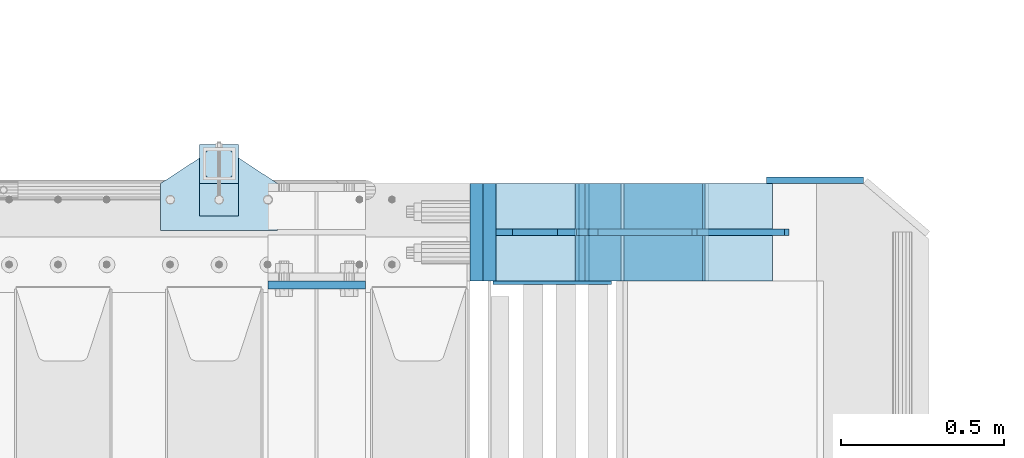
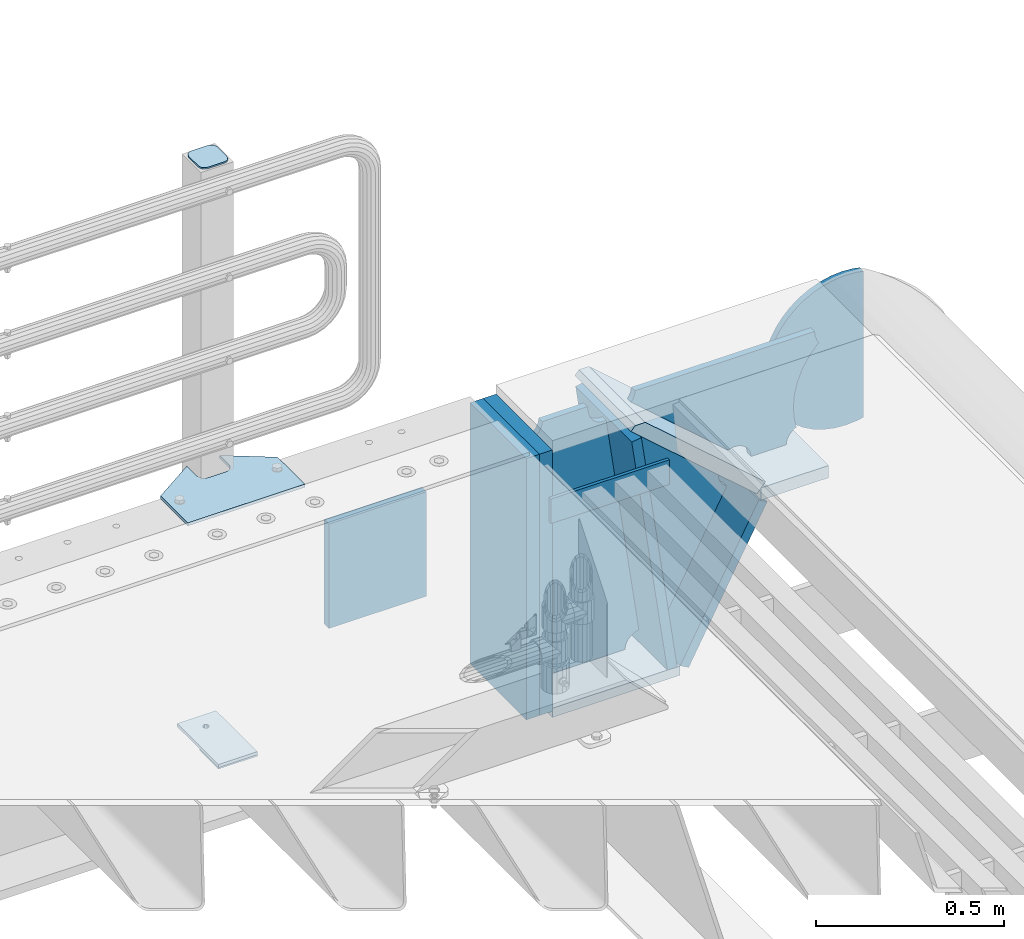
# One storey, part 243 of 257: 17 plates.
"""IFC2X3 building model written with IfcOpenShell, lengths in millimetres."""

import ifcopenshell
import ifcopenshell.guid

model = None  # the IFC model being written
_history = None  # IfcOwnerHistory: only IFC2X3 demands one
_inside = {}  # id of a spatial element -> (the spatial element, [elements in it])
_under = {}  # id of a project, library or spatial element -> (it, [spatial elements below it])
_declared = {}  # id of a project -> (the project, [libraries it declares])
_typed = {}  # id of a type object -> (the type object, [elements of that type])
_made_of = {}  # id of a material, layer set ... -> (it, [elements and type objects made of it])


def new_model(schema):
    """Start an empty IFC model of exactly this schema.

    Asked for "IFC4X3", IfcOpenShell would pick the latest addendum, in which some entities
    have other attributes; the version numbers below select the first issue.
    IFC2X3 requires an IfcOwnerHistory on every rooted entity: one is made here for all.
    """
    global model, _history
    if schema == "IFC4X3":
        model = ifcopenshell.file(schema_version=(4, 3, 0, 0))
    else:
        model = ifcopenshell.file(schema=schema)
    _inside.clear()
    _under.clear()
    _declared.clear()
    _typed.clear()
    _made_of.clear()
    _history = None
    if model.schema == "IFC2X3":
        org = make("IfcOrganization", Name="unknown")
        user = make(
            "IfcPersonAndOrganization",
            ThePerson=make("IfcPerson", FamilyName="unknown"),
            TheOrganization=org,
        )
        app = make(
            "IfcApplication",
            ApplicationDeveloper=org,
            Version="unknown",
            ApplicationFullName="unknown",
            ApplicationIdentifier="unknown",
        )
        _history = make(
            "IfcOwnerHistory",
            OwningUser=user,
            OwningApplication=app,
            ChangeAction="ADDED",
            CreationDate=0,
        )
    return model


def make(cls, **values):
    """One entity of the class cls with the attributes given. An attribute that is None is left unset."""
    return model.create_entity(
        cls, **{name: value for name, value in values.items() if value is not None}
    )


def rooted(cls, **values):
    """An entity with a GlobalId (a new one), such as an element, a storey or a relation."""
    return make(cls, GlobalId=ifcopenshell.guid.new(), OwnerHistory=_history, **values)


def si_unit(unit_type, name, prefix=None):
    """IfcSIUnit, for example si_unit("LENGTHUNIT", "METRE", prefix="MILLI")."""
    return make("IfcSIUnit", UnitType=unit_type, Prefix=prefix, Name=name)


def assignment(units):
    """IfcUnitAssignment: the units of a project."""
    return None if units is None else make("IfcUnitAssignment", Units=units)


def point(xyz):
    """IfcCartesianPoint."""
    return None if xyz is None else make("IfcCartesianPoint", Coordinates=xyz)


def direction(xyz):
    """IfcDirection."""
    return None if xyz is None else make("IfcDirection", DirectionRatios=xyz)


def frame(location, z_axis=None, x_axis=None):
    """IfcAxis2Placement3D, a coordinate frame: its origin and axes. An axis left out is left unset."""
    return make(
        "IfcAxis2Placement3D",
        Location=point(location),
        Axis=direction(z_axis),
        RefDirection=direction(x_axis),
    )


def origin_with_axes():
    """The frame at (0, 0, 0) with the z axis (0, 0, 1) and the x axis (1, 0, 0) written out."""
    return frame((0.0, 0.0, 0.0), z_axis=(0.0, 0.0, 1.0), x_axis=(1.0, 0.0, 0.0))


def place(relative_to, where):
    """IfcLocalPlacement: puts the frame where relative to a parent placement (None: the world)."""
    return make(
        "IfcLocalPlacement", PlacementRelTo=relative_to, RelativePlacement=where
    )


def context(
    kind, dimensions, precision=None, world=None, true_north=None, identifier=None
):
    """IfcGeometricRepresentationContext, for example the 3D "Model" context."""
    return make(
        "IfcGeometricRepresentationContext",
        ContextIdentifier=identifier,
        ContextType=kind,
        CoordinateSpaceDimension=dimensions,
        Precision=precision,
        WorldCoordinateSystem=world,
        TrueNorth=true_north,
    )


def subcontext(parent, identifier, kind, view, scale=None):
    """IfcGeometricRepresentationSubContext, for example "Body" below "Model"."""
    return make(
        "IfcGeometricRepresentationSubContext",
        ContextIdentifier=identifier,
        ContextType=kind,
        ParentContext=parent,
        TargetScale=scale,
        TargetView=view,
    )


def project(units=None, contexts=None):
    """IfcProject with its units and contexts."""
    return rooted(
        "IfcProject",
        Name="project",
        RepresentationContexts=contexts,
        UnitsInContext=assignment(units),
    )


def spatial(cls, under=None, at=None, **own):
    """A site, building, storey or space (cls), placed at a placement, below another one or the project."""
    s = rooted(cls, ObjectPlacement=at, **own)
    if under is not None:
        _under.setdefault(under.id(), (under, []))[1].append(s)
    return s


def faces_of(points, faces, orient=None, outer=None):
    """IfcFace entities. A face is a list of loops; a loop is a list of indices into points, from 0.

    orient and outer hold one flag for each loop. By default every Orientation is true, the
    first loop of a face is its IfcFaceOuterBound and the others are IfcFaceBound.
    """
    made = []
    for i, loops in enumerate(faces):
        bounds = []
        for j, loop in enumerate(loops):
            is_outer = j == 0 if outer is None else outer[i][j]
            bounds.append(
                make(
                    "IfcFaceOuterBound" if is_outer else "IfcFaceBound",
                    Bound=make("IfcPolyLoop", Polygon=[points[k] for k in loop]),
                    Orientation=True if orient is None else orient[i][j],
                )
            )
        made.append(make("IfcFace", Bounds=bounds))
    return made


def faceted_brep(points, faces, orient=None, outer=None, voids=None):
    """IfcFacetedBrep: a solid bounded by flat faces; with voids (closed shells), ...WithVoids."""
    shared = [point(p) for p in points]
    hull = make("IfcClosedShell", CfsFaces=faces_of(shared, faces, orient, outer))
    if voids is None:
        return make("IfcFacetedBrep", Outer=hull)
    return make(
        "IfcFacetedBrepWithVoids",
        Outer=hull,
        Voids=[
            make(cls, CfsFaces=faces_of(shared, fs, o, b)) for cls, fs, o, b in voids
        ],
    )


def shape(context_of_items, identifier, shape_type, items):
    """IfcShapeRepresentation: the items that make up one representation, for example the "Body"."""
    return make(
        "IfcShapeRepresentation",
        ContextOfItems=context_of_items,
        RepresentationIdentifier=identifier,
        RepresentationType=shape_type,
        Items=items,
    )


def material(Name=None, Category=None):
    """IfcMaterial."""
    return make("IfcMaterial", Name=Name, Category=Category)


def made_of(thing, what):
    """Note that an element or type object is made of a material, layer set ...; save() writes the relation."""
    if what is not None:
        _made_of.setdefault(what.id(), (what, []))[1].append(thing)
    return thing


def type_object(cls, material=None, **own):
    """A type object (cls), such as IfcWallType, which elements share."""
    return made_of(rooted(cls, **own), material)


def element(
    cls,
    number,
    at=None,
    inside=None,
    cuts=None,
    type_object=None,
    material=None,
    context=None,
    identifier="Body",
    shape_type=None,
    held_by="IfcProductDefinitionShape",
    body=None,
    shapes=None,
    **own,
):
    """One element of the class cls, such as IfcWall. Its Tag is "e" and its number.

    at: its placement. inside: the storey or other place that contains it. cuts: it is an
    opening in that element (IfcRelVoidsElement). A single representation is given by context,
    identifier, shape_type and body (its items); several are given by shapes. held_by: the class
    of the entity that holds the representations. save() writes the other relations.
    """
    e = rooted(cls, Tag="e%d" % number, ObjectPlacement=at, **own)
    if body is not None:
        shapes = [shape(context, identifier, shape_type, body)]
    if shapes is not None:
        e.Representation = make(held_by, Representations=shapes)
    if inside is not None:
        _inside.setdefault(inside.id(), (inside, []))[1].append(e)
    if cuts is not None:
        rooted(
            "IfcRelVoidsElement", RelatingBuildingElement=cuts, RelatedOpeningElement=e
        )
    if type_object is not None:
        _typed.setdefault(type_object.id(), (type_object, []))[1].append(e)
    return made_of(e, material)


def aggregate(whole, parts):
    """IfcRelAggregates: a whole, such as a stair, and the parts it consists of."""
    return rooted("IfcRelAggregates", RelatingObject=whole, RelatedObjects=parts)


def save(model, path):
    """Write the relations noted so far, then the file.

    IfcRelAggregates (storeys below a building ...), IfcRelContainedInSpatialStructure (elements
    in a storey), IfcRelDefinesByType, IfcRelAssociatesMaterial and IfcRelDeclares: one each for
    every whole, place, type object, material and project.
    """
    for whole, parts in _under.values():
        aggregate(whole, parts)
    for where, things in _inside.values():
        rooted(
            "IfcRelContainedInSpatialStructure",
            RelatedElements=things,
            RelatingStructure=where,
        )
    for kind, things in _typed.values():
        rooted("IfcRelDefinesByType", RelatedObjects=things, RelatingType=kind)
    for what, things in _made_of.values():
        rooted("IfcRelAssociatesMaterial", RelatedObjects=things, RelatingMaterial=what)
    for by, libraries in _declared.values():
        rooted("IfcRelDeclares", RelatingContext=by, RelatedDefinitions=libraries)
    model.write(path)


model = new_model("IFC2X3")

# Units and contexts
model_context = context("Model", 3, precision=1e-05, world=origin_with_axes())
body_context = subcontext(model_context, "Body", "Model", "MODEL_VIEW")
ifc_project = project(units=[si_unit("LENGTHUNIT", "METRE", prefix="MILLI"), si_unit("AREAUNIT", "SQUARE_METRE"), si_unit("VOLUMEUNIT", "CUBIC_METRE"), si_unit("MASSUNIT", "GRAM", prefix="KILO"), si_unit("TIMEUNIT", "SECOND"), si_unit("PLANEANGLEUNIT", "RADIAN"), si_unit("SOLIDANGLEUNIT", "STERADIAN"), si_unit("THERMODYNAMICTEMPERATUREUNIT", "DEGREE_CELSIUS"), si_unit("LUMINOUSINTENSITYUNIT", "LUMEN")], contexts=[model_context])

# Site, building, storey
site_placement = place(None, origin_with_axes())
site = spatial("IfcSite", under=ifc_project, at=site_placement, CompositionType="ELEMENT")
building_placement = place(site_placement, origin_with_axes())
building = spatial("IfcBuilding", under=site, at=building_placement, Name="Standard", CompositionType="ELEMENT")
storey_placement = place(building_placement, origin_with_axes())
storey = spatial("IfcBuildingStorey", under=building, at=storey_placement, Name="Undefined", CompositionType="ELEMENT", Elevation=0.0)

# Plates
ifc_material_1 = material(Name="STEEL/S355N")
plate_type_1 = type_object("IfcPlateType", PredefinedType="NOTDEFINED")
plate_1_placement = place(storey_placement, frame((58645.0, 11837.5, -340.000000000044), z_axis=(0.0, 0.0, 1.0), x_axis=(1.0, 0.0, 0.0)))
element("IfcPlate", 1, at=plate_1_placement, inside=storey, type_object=plate_type_1, material=ifc_material_1, context=body_context, shape_type="Brep", body=[
    faceted_brep([(0.0, -12.5, 0.0), (0.0, -12.5, 340.0), (0.0, 12.5, 340.0), (0.0, 12.5, 0.0), (300.0, -12.5, 340.0), (300.0, 12.5, 340.0), (300.0, -12.5, 0.0), (300.0, 12.5, 0.0)], [[[0, 1, 2, 3]], [[1, 4, 5, 2]], [[4, 6, 7, 5]], [[6, 0, 3, 7]], [[5, 7, 3, 2]], [[6, 4, 1, 0]]]),
])
ifc_material_2 = material()
plate_type_2 = type_object("IfcPlateType", PredefinedType="NOTDEFINED")
plate_2_placement = place(storey_placement, frame((59287.0, 12150.0, -870.0), z_axis=(0.0, 0.0, 1.0), x_axis=(0.0, -1.0, 0.0)))
element("IfcPlate", 2, at=plate_2_placement, inside=storey, type_object=plate_type_2, material=ifc_material_2, context=body_context, shape_type="Brep", body=[
    faceted_brep([(0.0, -20.0, 0.0), (0.0, -20.0, 850.0), (0.0, 20.0, 850.0), (0.0, 20.0, 0.0), (300.0, -20.0, 850.0), (300.0, 20.0, 850.0), (300.0, -20.0, -1.81898940354586e-12), (300.0, 20.0, -1.81898940354586e-12)], [[[0, 1, 2, 3]], [[1, 4, 5, 2]], [[4, 6, 7, 5]], [[6, 0, 3, 7]], [[5, 7, 3, 2]], [[6, 4, 1, 0]]]),
])
plate_3_placement = place(storey_placement, frame((59988.9988298898, 12149.9999999992, -367.999999999302), z_axis=(-0.752989422949573, 0.0, 0.658032619955933), x_axis=(0.0, -1.0, 0.0)))
element("IfcPlate", 3, at=plate_3_placement, inside=storey, type_object=plate_type_2, material=ifc_material_1, context=body_context, shape_type="Brep", body=[
    faceted_brep([(-8.10757683211705e-10, 20.0, 490.766265601618), (4.54747350886464e-13, -0.303811250938452, 513.999999999993), (300.0, -0.303811250938452, 513.999999999993), (300.0, 20.0, 490.766265601618), (300.0, -20.0, -1.81898940354586e-12), (300.0, -19.9999999999927, 513.999999999993), (4.54747350886464e-13, -19.9999999999927, 513.999999999993), (0.0, -20.0, 0.0), (0.0, 20.0, 0.0), (300.0, 20.0, -1.81898940354586e-12)], [[[0, 1, 2, 3]], [[4, 5, 6, 7]], [[4, 7, 8, 9]], [[9, 8, 0, 3]], [[5, 4, 9, 3, 2]], [[6, 5, 2, 1]], [[8, 7, 6, 1, 0]]]),
])
plate_4_placement = place(storey_placement, frame((59326.9988298906, 12150.0, -870.000000000003), z_axis=(0.0, 0.0, 1.0), x_axis=(0.0, -1.0, 0.0)))
element("IfcPlate", 4, at=plate_4_placement, inside=storey, type_object=plate_type_2, material=ifc_material_2, context=body_context, shape_type="Brep", body=[
    faceted_brep([(0.0, -20.0, 0.0), (0.0, -20.0, 850.0), (0.0, 20.0, 850.0), (0.0, 20.0, 0.0), (300.0, -20.0, 850.0), (300.0, 20.0, 850.0), (300.0, -20.0, -1.81898940354586e-12), (300.0, 20.0, -1.81898940354586e-12)], [[[0, 1, 2, 3]], [[1, 4, 5, 2]], [[4, 6, 7, 5]], [[6, 0, 3, 7]], [[5, 7, 3, 2]], [[6, 4, 1, 0]]]),
])
ifc_material_3 = material(Name="STEEL/S355J2")
plate_type_3 = type_object("IfcPlateType", PredefinedType="NOTDEFINED")
plate_5_placement = place(storey_placement, frame((58315.0, 12005.0, 5.00000000004911), z_axis=(0.0, 1.0, 0.0), x_axis=(1.0, 0.0, 0.0)))
element("IfcPlate", 5, at=plate_5_placement, inside=storey, type_object=plate_type_3, material=ifc_material_3, context=body_context, shape_type="Brep", body=[
    faceted_brep([(0.0, -5.0, 0.0), (2.31396552408114e-06, -5.0, 145.0), (2.31396552408114e-06, 5.0, 145.0), (0.0, 5.0, 0.0), (130.0, -5.0, 230.0), (130.0, 5.0, 230.0), (130.0, -5.0, 180.0), (130.0, 5.0, 180.0), (130.48036798992, -5.0, 175.122741949597), (130.48036798992, 5.0, 175.122741949597), (131.903011687216, -5.0, 170.432914190873), (131.903011687216, 5.0, 170.432914190873), (134.213259692435, -5.0, 166.11074417451), (134.213259692435, 5.0, 166.11074417451), (137.322330470335, -5.0, 162.322330470337), (137.322330470335, 5.0, 162.322330470337), (141.110744174512, -5.0, 159.213259692437), (141.110744174512, 5.0, 159.213259692437), (145.432914190875, -5.0, 156.903011687218), (145.432914190875, 5.0, 156.903011687218), (150.122741949599, -5.0, 155.48036798992), (150.122741949599, 5.0, 155.48036798992), (155.0, -5.0, 155.0), (155.0, 5.0, 155.0), (205.0, -5.0, 155.0), (205.0, 5.0, 155.0), (209.877258050401, -5.0, 155.48036798992), (209.877258050401, 5.0, 155.48036798992), (214.567085809125, -5.0, 156.903011687218), (214.567085809125, 5.0, 156.903011687218), (218.889255825488, -5.0, 159.213259692437), (218.889255825488, 5.0, 159.213259692437), (222.677669529665, -5.0, 162.322330470337), (222.677669529665, 5.0, 162.322330470337), (225.786740307565, -5.0, 166.11074417451), (225.786740307565, 5.0, 166.11074417451), (228.096988312784, -5.0, 170.432914190873), (228.096988312784, 5.0, 170.432914190873), (229.51963201008, -5.0, 175.122741949597), (229.51963201008, 5.0, 175.122741949597), (230.0, -5.0, 180.0), (230.0, 5.0, 180.0), (230.0, -5.0, 230.0), (230.0, 5.0, 230.0), (360.0, -5.0, 145.0), (360.0, 5.0, 145.0), (360.0, -5.0, -7.27595761418343e-12), (360.0, 5.0, -7.27595761418343e-12)], [[[0, 1, 2, 3]], [[1, 4, 5, 2]], [[4, 6, 7, 5]], [[6, 8, 9, 7]], [[8, 10, 11, 9]], [[10, 12, 13, 11]], [[12, 14, 15, 13]], [[14, 16, 17, 15]], [[16, 18, 19, 17]], [[18, 20, 21, 19]], [[20, 22, 23, 21]], [[22, 24, 25, 23]], [[24, 26, 27, 25]], [[26, 28, 29, 27]], [[28, 30, 31, 29]], [[30, 32, 33, 31]], [[32, 34, 35, 33]], [[34, 36, 37, 35]], [[36, 38, 39, 37]], [[38, 40, 41, 39]], [[40, 42, 43, 41]], [[42, 44, 45, 43]], [[44, 46, 47, 45]], [[46, 0, 3, 47]], [[5, 7, 9, 11, 13, 15, 17, 19, 21, 23, 25, 27, 29, 31, 33, 35, 37, 39, 41, 43, 45, 47, 3, 2]], [[46, 44, 42, 40, 38, 36, 34, 32, 30, 28, 26, 24, 22, 20, 18, 16, 14, 12, 10, 8, 6, 4, 1, 0]]]),
])
plate_type_4 = type_object("IfcPlateType", PredefinedType="NOTDEFINED")
plate_6_placement = place(storey_placement, frame((58435.0000000001, 12050.0000000002, -850.000000000002), z_axis=(0.0, 1.0, 0.0), x_axis=(1.0, 0.0, 0.0)))
element("IfcPlate", 6, at=plate_6_placement, inside=storey, type_object=plate_type_4, material=ifc_material_3, context=body_context, shape_type="Brep", body=[
    faceted_brep([(66.3639610305399, -5.0, 163.636038969113), (66.3639610305399, 5.0, 163.636038969113), (59.9999999998618, 5.0, 160.999999999791), (59.9999999998618, -5.0, 160.999999999791), (53.6360389691836, 5.0, 163.636038969113), (53.6360389691836, -5.0, 163.636038969113), (50.9999999998618, 5.0, 169.999999999791), (50.9999999998618, -5.0, 169.999999999791), (53.6360389691836, 5.0, 176.363961030469), (53.6360389691836, -5.0, 176.363961030469), (59.9999999998618, 5.0, 178.999999999791), (59.9999999998618, -5.0, 178.999999999791), (66.3639610305399, 5.0, 176.363961030469), (66.3639610305399, -5.0, 176.363961030469), (68.9999999998618, 5.0, 169.999999999791), (68.9999999998618, -5.0, 169.999999999791), (120.0, -5.0, 0.0), (120.0, -5.0, 220.0), (0.0, -5.0, 220.0), (0.0, -5.0, 0.0), (0.0, 5.0, 0.0), (120.0, 5.0, 0.0), (120.0, 5.0, 220.0), (0.0, 5.0, 220.0)], [[[0, 1, 2, 3]], [[3, 2, 4, 5]], [[5, 4, 6, 7]], [[7, 6, 8, 9]], [[9, 8, 10, 11]], [[11, 10, 12, 13]], [[13, 12, 14, 15]], [[15, 14, 1, 0]], [[16, 17, 18, 19], [3, 5, 7, 9, 11, 13, 15, 0]], [[16, 19, 20, 21]], [[17, 16, 21, 22]], [[18, 17, 22, 23]], [[19, 18, 23, 20]], [[22, 21, 20, 23], [10, 8, 6, 4, 2, 1, 14, 12]]]),
])
plate_type_5 = type_object("IfcPlateType", PredefinedType="NOTDEFINED")
plate_7_placement = place(storey_placement, frame((58539.0000000001, 12166.0000000002, 1012.50000000001), z_axis=(0.0, 1.0, 0.0), x_axis=(-1.0, 0.0, 0.0)))
element("IfcPlate", 7, at=plate_7_placement, inside=storey, type_object=plate_type_5, material=ifc_material_3, context=body_context, shape_type="Brep", body=[
    faceted_brep([(0.0, -2.5, 19.0), (0.0, -2.5, 69.0), (0.0, 2.5, 69.0), (0.0, 2.5, 19.0), (0.476369668547704, -2.5, 73.2278977451697), (0.476369668547704, 2.5, 73.2278977451697), (1.88159150985302, -2.5, 77.2437910432327), (1.88159150985302, 2.5, 77.2437910432327), (4.14520183311106, -2.5, 80.8463062353167), (4.14520183311106, 2.5, 80.8463062353167), (7.15369376468152, -2.5, 83.8547981668926), (7.15369376468152, 2.5, 83.8547981668926), (10.7562089567655, -2.5, 86.1184084901452), (10.7562089567655, 2.5, 86.1184084901452), (14.7721022548285, -2.5, 87.5236303314541), (14.7721022548285, 2.5, 87.5236303314541), (19.0, -2.5, 88.0), (19.0, 2.5, 88.0), (69.0, -2.5, 88.0), (69.0, 2.5, 88.0), (73.2278977451715, -2.5, 87.5236303314541), (73.2278977451715, 2.5, 87.5236303314541), (77.2437910432345, -2.5, 86.1184084901452), (77.2437910432345, 2.5, 86.1184084901452), (80.8463062353185, -2.5, 83.8547981668926), (80.8463062353185, 2.5, 83.8547981668926), (83.8547981668889, -2.5, 80.8463062353167), (83.8547981668889, 2.5, 80.8463062353167), (86.118408490147, -2.5, 77.2437910432327), (86.118408490147, 2.5, 77.2437910432327), (87.5236303314523, -2.5, 73.2278977451697), (87.5236303314523, 2.5, 73.2278977451697), (88.0, -2.5, 69.0), (88.0, 2.5, 69.0), (88.0, -2.5, 19.0), (88.0, 2.5, 19.0), (87.5236303314523, -2.5, 14.7721022548303), (87.5236303314523, 2.5, 14.7721022548303), (86.118408490147, -2.5, 10.7562089567673), (86.118408490147, 2.5, 10.7562089567673), (83.8547981668889, -2.5, 7.15369376468334), (83.8547981668889, 2.5, 7.15369376468334), (80.8463062353185, -2.5, 4.14520183310742), (80.8463062353185, 2.5, 4.14520183310742), (77.2437910432345, -2.5, 1.88159150985484), (77.2437910432345, 2.5, 1.88159150985484), (73.2278977451715, -2.5, 0.476369668545885), (73.2278977451715, 2.5, 0.476369668545885), (69.0, -2.5, 0.0), (69.0, 2.5, 0.0), (19.0, -2.5, 0.0), (19.0, 2.5, 0.0), (14.7721022548285, -2.5, 0.476369668545885), (14.7721022548285, 2.5, 0.476369668545885), (10.7562089567655, -2.5, 1.88159150985484), (10.7562089567655, 2.5, 1.88159150985484), (7.15369376468152, -2.5, 4.14520183310742), (7.15369376468152, 2.5, 4.14520183310742), (4.14520183311106, -2.5, 7.15369376468334), (4.14520183311106, 2.5, 7.15369376468334), (1.88159150985302, -2.5, 10.7562089567673), (1.88159150985302, 2.5, 10.7562089567673), (0.476369668547704, -2.5, 14.7721022548303), (0.476369668547704, 2.5, 14.7721022548303)], [[[0, 1, 2, 3]], [[1, 4, 5, 2]], [[4, 6, 7, 5]], [[6, 8, 9, 7]], [[8, 10, 11, 9]], [[10, 12, 13, 11]], [[12, 14, 15, 13]], [[14, 16, 17, 15]], [[16, 18, 19, 17]], [[18, 20, 21, 19]], [[20, 22, 23, 21]], [[22, 24, 25, 23]], [[24, 26, 27, 25]], [[26, 28, 29, 27]], [[28, 30, 31, 29]], [[30, 32, 33, 31]], [[32, 34, 35, 33]], [[34, 36, 37, 35]], [[36, 38, 39, 37]], [[38, 40, 41, 39]], [[40, 42, 43, 41]], [[42, 44, 45, 43]], [[44, 46, 47, 45]], [[46, 48, 49, 47]], [[48, 50, 51, 49]], [[50, 52, 53, 51]], [[52, 54, 55, 53]], [[54, 56, 57, 55]], [[56, 58, 59, 57]], [[58, 60, 61, 59]], [[60, 62, 63, 61]], [[62, 0, 3, 63]], [[5, 7, 9, 11, 13, 15, 17, 19, 21, 23, 25, 27, 29, 31, 33, 35, 37, 39, 41, 43, 45, 47, 49, 51, 53, 55, 57, 59, 61, 63, 3, 2]], [[62, 60, 58, 56, 54, 52, 50, 48, 46, 44, 42, 40, 38, 36, 34, 32, 30, 28, 26, 24, 22, 20, 18, 16, 14, 12, 10, 8, 6, 4, 1, 0]]]),
])
plate_type_6 = type_object("IfcPlateType", PredefinedType="NOTDEFINED")
plate_8_placement = place(storey_placement, frame((58435.0000000001, 12050.0000000002, -857.500000000002), z_axis=(0.0, 1.0, 0.0), x_axis=(1.0, 0.0, 0.0)))
element("IfcPlate", 8, at=plate_8_placement, inside=storey, type_object=plate_type_6, material=ifc_material_3, context=body_context, shape_type="Brep", body=[
    faceted_brep([(0.0, -2.5, 0.0), (0.0, -2.5, 100.0), (0.0, 2.5, 100.0), (0.0, 2.5, 0.0), (120.0, -2.5, 100.0), (120.0, 2.5, 100.0), (120.0, -2.5, 0.0), (120.0, 2.5, 0.0)], [[[0, 1, 2, 3]], [[1, 4, 5, 2]], [[4, 6, 7, 5]], [[6, 0, 3, 7]], [[5, 7, 3, 2]], [[6, 4, 1, 0]]]),
])
plate_type_7 = type_object("IfcPlateType", PredefinedType="NOTDEFINED")
plate_9_placement = place(storey_placement, frame((59988.9988298898, 11849.9999999992, -387.999999999302), z_axis=(1.0, 0.0, 0.0), x_axis=(0.0, 1.0, 0.0)))
element("IfcPlate", 9, at=plate_9_placement, inside=storey, type_object=plate_type_7, material=ifc_material_1, context=body_context, shape_type="Brep", body=[
    faceted_brep([(0.0, -20.0, 0.0), (3.31056071445346e-10, -20.0, 208.0), (3.31056071445346e-10, 20.0, 208.0), (0.0, 20.0, 0.0), (300.0, -20.0, 208.0), (300.0, 20.0, 208.0), (300.0, -20.0, -1.81898940354586e-12), (300.0, 20.0, -1.81898940354586e-12)], [[[0, 1, 2, 3]], [[1, 4, 5, 2]], [[4, 6, 7, 5]], [[6, 0, 3, 7]], [[5, 7, 3, 2]], [[6, 4, 1, 0]]]),
])
plate_type_8 = type_object("IfcPlateType", PredefinedType="NOTDEFINED")
plate_10_placement = place(storey_placement, frame((59739.9988298891, 12150.0, -875.000000003253), z_axis=(0.0, -1.0, 0.0), x_axis=(-1.0, 0.0, 0.0)))
element("IfcPlate", 10, at=plate_10_placement, inside=storey, type_object=plate_type_8, material=ifc_material_1, context=body_context, shape_type="Brep", body=[
    faceted_brep([(0.0, -15.0, 0.0), (0.0, -15.0, 300.0), (0.0, 15.0, 300.0), (0.0, 15.0, 0.0), (393.0, -15.0, 300.0), (393.0, 15.0, 300.0), (393.0, -15.0, 1.50635059981141e-12), (393.0, 15.0, 1.50635059981141e-12)], [[[0, 1, 2, 3]], [[1, 4, 5, 2]], [[4, 6, 7, 5]], [[6, 0, 3, 7]], [[5, 7, 3, 2]], [[6, 4, 1, 0]]]),
])
plate_11_placement = place(storey_placement, frame((59716.1480677219, 12150.000000001, -862.083788721732), z_axis=(-0.139173011053008, 0.0, 0.990268081377179), x_axis=(0.0, -1.0, 0.0)))
element("IfcPlate", 11, at=plate_11_placement, inside=storey, type_object=plate_type_8, material=ifc_material_1, context=body_context, shape_type="Brep", body=[
    faceted_brep([(1.00411057246674e-09, 14.9994702460463, -0.00376939772104379), (300.0, 15.0, 0.0), (300.0, -15.0, 4.21237841382026), (0.0, -15.0, 4.21237841382026), (0.0, -15.0000000000073, 792.000000000002), (300.0, -15.0000000000073, 792.000000000002), (300.0, 14.9999999999927, 792.000000000002), (0.0, 14.9999999999927, 792.000000000002)], [[[0, 1, 2, 3]], [[4, 5, 6, 7]], [[4, 7, 0, 3]], [[5, 4, 3, 2]], [[6, 5, 2, 1]], [[7, 6, 1, 0]]]),
])
plate_12_placement = place(storey_placement, frame((59753.2468009566, 12150.000000001, -867.038754739308), z_axis=(0.469471552246179, 0.0, 0.882947598462991), x_axis=(0.0, -1.0, 0.0)))
element("IfcPlate", 12, at=plate_12_placement, inside=storey, type_object=plate_type_8, material=ifc_material_1, context=body_context, shape_type="Brep", body=[
    faceted_brep([(0.0, -15.0, 0.0), (0.0, -15.0, 514.999999999996), (0.0, 15.0, 515.0), (0.0, 15.0, 0.0), (300.0, -15.0, 514.999999999996), (300.0, 15.0, 515.0), (300.0, -15.0, 0.0), (300.0, 15.0, 0.0)], [[[0, 1, 2, 3]], [[1, 4, 5, 2]], [[4, 6, 7, 5]], [[6, 0, 3, 7]], [[5, 7, 3, 2]], [[6, 4, 1, 0]]]),
])
plate_type_9 = type_object("IfcPlateType", PredefinedType="NOTDEFINED")
plate_13_placement = place(storey_placement, frame((60303.9988298898, 11999.9999999994, -29.9999999993023), z_axis=(-0.000446694000102124, 0.0, -0.99999990023223), x_axis=(-0.99999990023223, 0.0, 0.000446694000103734)))
element("IfcPlate", 13, at=plate_13_placement, inside=storey, type_object=plate_type_9, material=ifc_material_1, context=body_context, shape_type="Brep", body=[
    faceted_brep([(125.007775472979, 10.0, 291.842314882028), (131.755016800045, 10.0, 263.793234614468), (131.755016800045, -10.0, 263.793234614468), (125.007775472979, -10.0, 291.842314882028), (134.899927074475, 10.0, 224.060281342732), (134.899927074475, -10.0, 224.060281342732), (131.790514995213, 10.0, 184.324534302446), (131.790514995213, -10.0, 184.324534302446), (122.503344607198, 10.0, 145.564419461128), (122.503344607198, -10.0, 145.564419461128), (107.267096867741, 10.0, 108.734339483615), (107.267096867741, -10.0, 108.734339483615), (86.4569387623851, 10.0, 74.7411731709829), (86.4569387623851, -10.0, 74.7411731709829), (60.5852854486438, 10.0, 44.4219450946983), (60.5852854486438, -10.0, 44.4219450946983), (56.2519855253049, 10.0, 40.7176084148918), (56.2519855253049, -10.0, 40.7176084148918), (136.409234539118, -10.0, 297.721677540594), (147.386991180581, -10.0, 308.778803581017), (147.386991180581, 10.0, 308.778803581017), (136.409234539118, 10.0, 297.721677540594), (154.428166132762, -10.0, 322.678193223937), (154.428166132762, 10.0, 322.678193223937), (156.84900166298, -10.0, 338.070097995228), (156.84900166298, 10.0, 338.070097995228), (264.849004013289, -10.0, 338.118348049693), (264.849004013289, 10.0, 338.118348049693), (267.628767119546, -10.0, 321.701412969031), (267.628767119546, 10.0, 321.701412969031), (275.645118712171, -10.0, 307.107546191754), (275.645118712171, 10.0, 307.107546191754), (288.009068357205, -10.0, 295.955165748785), (288.009068357205, 10.0, 295.955165748785), (303.34948944753, -10.0, 289.481038692482), (303.34948944753, 10.0, 289.481038692482), (319.96517321693, -10.0, 288.403127172445), (319.96517321693, 10.0, 288.403127172445), (336.013487920231, -10.0, 292.840968489265), (336.013487920231, 10.0, 292.840968489265), (335.869079589844, -10.0, 293.150054931641), (335.869079589844, 10.0, 293.150054931641), (633.937057436437, -10.0, 32.8861672876965), (633.937057436437, 10.0, 32.8861672876965), (628.672097726398, -10.0, 25.6357574923157), (628.672097726398, 10.0, 25.6357574923157), (624.785781531267, -10.0, 17.5620477266101), (624.785781531267, 10.0, 17.5620477266101), (622.402919050604, -10.0, 8.92432757904926), (622.402919050604, 10.0, 8.92432757904926), (621.600036621094, -10.0, -8.74677219542264e-10), (621.600036621094, 10.0, -8.74677219542264e-10), (70.0, -10.0, -9.84980985663242e-11), (70.0, 10.0, -9.84980985663242e-11), (67.7728137216545, -10.0, 17.5170123094482), (67.7728137216545, 10.0, 17.5170123094482), (61.232979421402, -10.0, 33.9193489203215), (61.232979421402, 10.0, 33.9193489203215)], [[[0, 1, 2, 3]], [[4, 5, 2, 1]], [[6, 7, 5, 4]], [[8, 9, 7, 6]], [[10, 11, 9, 8]], [[12, 13, 11, 10]], [[14, 15, 13, 12]], [[16, 17, 15, 14]], [[18, 19, 20, 21]], [[19, 22, 23, 20]], [[22, 24, 25, 23]], [[24, 26, 27, 25]], [[26, 28, 29, 27]], [[28, 30, 31, 29]], [[30, 32, 33, 31]], [[32, 34, 35, 33]], [[34, 36, 37, 35]], [[36, 38, 39, 37]], [[38, 40, 41, 39]], [[40, 42, 43, 41]], [[42, 44, 45, 43]], [[44, 46, 47, 45]], [[46, 48, 49, 47]], [[48, 50, 51, 49]], [[50, 52, 53, 51]], [[52, 54, 55, 53]], [[54, 56, 57, 55]], [[12, 10, 8, 6, 4, 1, 0, 21, 20, 23, 25, 27, 29, 31, 33, 35, 37, 39, 41, 43, 45, 47, 49, 51, 53, 55, 57, 16, 14]], [[18, 21, 0, 3]], [[56, 54, 52, 50, 48, 46, 44, 42, 40, 38, 36, 34, 32, 30, 28, 26, 24, 22, 19, 18, 3, 2, 5, 7, 9, 11, 13, 15, 17]], [[57, 56, 17, 16]]]),
])
plate_type_10 = type_object("IfcPlateType", PredefinedType="NOTDEFINED")
plate_14_placement = place(storey_placement, frame((59988.0025685034, 12000.000000001, -393.996688204407), z_axis=(-0.658066357015093, 0.0, -0.752959939017266), x_axis=(-0.75295993901727, 0.0, 0.658066357015088)))
element("IfcPlate", 14, at=plate_14_placement, inside=storey, type_object=plate_type_10, material=ifc_material_1, context=body_context, shape_type="Brep", body=[
    faceted_brep([(-11.3595226159669, -10.0, 48.6925173505879), (-112.015767301047, -10.0, 480.154833723624), (-112.015767301047, 10.0, 480.154833723624), (-11.3595226159669, 10.0, 48.6925173505879), (-104.567323293646, -10.0, 482.519601382533), (-104.567323293646, 10.0, 482.519601382533), (-97.5783311600098, -10.0, 486.016090073754), (-97.5783311600098, 10.0, 486.016090073754), (-91.2195220373906, -10.0, 490.558885551647), (-91.2195220373906, 10.0, 490.558885551647), (-85.6462325884277, -10.0, 496.037013784), (-85.6462325884277, 10.0, 496.037013784), (447.024482710491, -10.0, 32.8103372896294), (447.024482710491, 10.0, 32.8103372896294), (441.786973010385, -10.0, 25.5709623937219), (441.786973010385, 10.0, 25.5709623937219), (437.921644570117, -10.0, 17.5149526624009), (437.921644570117, 10.0, 17.5149526624009), (435.551940606492, -10.0, 8.89958500531066), (435.551940606492, 10.0, 8.89958500531066), (434.753540039055, -10.0, -5.23868948221207e-10), (434.753540039055, 10.0, -5.23868948221207e-10), (50.0, -10.0, 0.0), (50.0, 10.0, 0.0), (47.7668538974176, -10.0, 14.7759151575083), (47.7668538974176, 10.0, 14.7759151575083), (41.2668932502784, -10.0, 28.231959221237), (41.2668932502784, 10.0, 28.231959221237), (31.080732530012, -10.0, 39.1661596968261), (31.080732530012, 10.0, 39.1661596968261), (18.1182591411343, -10.0, 46.6018098971836), (18.1182591411343, 10.0, 46.6018098971836), (3.53735696079821, -10.0, 49.8747140917258), (3.53735696079821, 10.0, 49.8747140917258)], [[[0, 1, 2, 3]], [[1, 4, 5, 2]], [[4, 6, 7, 5]], [[6, 8, 9, 7]], [[8, 10, 11, 9]], [[10, 12, 13, 11]], [[12, 14, 15, 13]], [[14, 16, 17, 15]], [[16, 18, 19, 17]], [[18, 20, 21, 19]], [[20, 22, 23, 21]], [[22, 24, 25, 23]], [[24, 26, 27, 25]], [[26, 28, 29, 27]], [[28, 30, 31, 29]], [[30, 32, 33, 31]], [[32, 0, 3, 33]], [[5, 7, 9, 11, 13, 15, 17, 19, 21, 23, 25, 27, 29, 31, 33, 3, 2]], [[32, 30, 28, 26, 24, 22, 20, 18, 16, 14, 12, 10, 8, 6, 4, 1, 0]]]),
])
plate_type_11 = type_object("IfcPlateType", PredefinedType="NOTDEFINED")
plate_15_placement = place(storey_placement, frame((59585.998829889, 12000.0, -30.0000000032531), z_axis=(0.0, 0.0, -1.0), x_axis=(-1.0, 0.0, 0.0)))
element("IfcPlate", 15, at=plate_15_placement, inside=storey, type_object=plate_type_11, material=ifc_material_1, context=body_context, shape_type="Brep", body=[
    faceted_brep([(-9.00602409638668, -10.0, 65.0), (-108.137843376921, -10.0, 780.473130459514), (-108.137843376921, 10.0, 780.473130459514), (-9.00602409638668, 10.0, 65.0), (-94.4157884488377, -10.0, 784.433672138112), (-94.4157884488377, 10.0, 784.433672138112), (-82.3732461236723, -10.0, 792.112074067144), (-82.3732461236723, 10.0, 792.112074067144), (-72.9927947992401, -10.0, 802.881837982249), (-72.9927947992401, 10.0, 802.881837982249), (-67.0398068183713, -10.0, 815.864234368775), (-67.0398068183713, 10.0, 815.864234368775), (-65.0, -10.0, 830.0), (-65.0, 10.0, 830.0), (189.0, -10.0, 830.0), (189.0, 10.0, 830.0), (191.447174185239, -10.0, 814.549150281253), (191.447174185239, 10.0, 814.549150281253), (198.549150281251, -10.0, 800.610737385376), (198.549150281251, 10.0, 800.610737385376), (209.610737385374, -10.0, 789.549150281253), (209.610737385374, 10.0, 789.549150281253), (223.549150281251, -10.0, 782.447174185242), (223.549150281251, 10.0, 782.447174185242), (239.0, -10.0, 780.0), (239.0, 10.0, 780.0), (239.0, -10.0, 50.0), (239.0, 10.0, 50.0), (223.549150281251, -10.0, 47.5528258147577), (223.549150281251, 10.0, 47.5528258147577), (209.610737385374, -10.0, 40.4508497187474), (209.610737385374, 10.0, 40.4508497187474), (198.549150281251, -10.0, 29.3892626146237), (198.549150281251, 10.0, 29.3892626146237), (191.447174185239, -10.0, 15.4508497187474), (191.447174185239, 10.0, 15.4508497187474), (189.0, -10.0, 0.0), (189.0, 10.0, 0.0), (50.4776502774184, -10.0, 0.0), (50.4776502774184, 10.0, 0.0), (47.3830020671812, -10.0, 22.3352870825933), (47.3830020671812, 10.0, 22.3352870825933), (42.8384615202813, -10.0, 37.3040735979326), (42.8384615202813, 10.0, 37.3040735979326), (33.8907372011745, -10.0, 50.1358952937587), (33.8907372011745, 10.0, 50.1358952937587), (21.415694708674, -10.0, 59.5746840579253), (21.415694708674, 10.0, 59.5746840579253), (6.63447812067898, -10.0, 64.6965054822873), (6.63447812067898, 10.0, 64.6965054822873)], [[[0, 1, 2, 3]], [[1, 4, 5, 2]], [[4, 6, 7, 5]], [[6, 8, 9, 7]], [[8, 10, 11, 9]], [[10, 12, 13, 11]], [[12, 14, 15, 13]], [[14, 16, 17, 15]], [[16, 18, 19, 17]], [[18, 20, 21, 19]], [[20, 22, 23, 21]], [[22, 24, 25, 23]], [[24, 26, 27, 25]], [[26, 28, 29, 27]], [[28, 30, 31, 29]], [[30, 32, 33, 31]], [[32, 34, 35, 33]], [[34, 36, 37, 35]], [[36, 38, 39, 37]], [[38, 40, 41, 39]], [[40, 42, 43, 41]], [[42, 44, 45, 43]], [[44, 46, 47, 45]], [[46, 48, 49, 47]], [[48, 0, 3, 49]], [[5, 7, 9, 11, 13, 15, 17, 19, 21, 23, 25, 27, 29, 31, 33, 35, 37, 39, 41, 43, 45, 47, 49, 3, 2]], [[48, 46, 44, 42, 40, 38, 36, 34, 32, 30, 28, 26, 24, 22, 20, 18, 16, 14, 12, 10, 8, 6, 4, 1, 0]]]),
])
plate_type_12 = type_object("IfcPlateType", PredefinedType="NOTDEFINED")
plate_16_placement = place(storey_placement, frame((60666.9988298906, 12160.0, -498.000000000001), z_axis=(0.0, 0.0, 1.0), x_axis=(-1.0, 0.0, 0.0)))
element("IfcPlate", 16, at=plate_16_placement, inside=storey, type_object=plate_type_12, material=ifc_material_1, context=body_context, shape_type="Brep", body=[
    faceted_brep([(244.0, -10.0, 0.0), (209.275179461321, -10.0, 2.48356818105242), (209.275179461321, 10.0, 2.48356818105242), (244.0, 10.0, 0.0), (278.724820538679, -10.0, 2.48356818105236), (278.724820538679, 10.0, 2.48356818105236), (312.742743869312, -10.0, 9.88371443806261), (312.742743869312, 10.0, 9.88371443806261), (345.361263172461, -10.0, 22.0497931334975), (345.361263172461, 10.0, 22.0497931334975), (375.916359459166, -10.0, 38.7341379891918), (375.916359459166, 10.0, 38.7341379891918), (403.786019082647, -10.0, 59.597103857561), (403.786019082647, 10.0, 59.597103857561), (428.402896142441, -10.0, 84.2139809173505), (428.402896142441, 10.0, 84.2139809173505), (449.265862010805, -10.0, 112.083640540834), (449.265862010805, 10.0, 112.083640540834), (465.950206866502, -10.0, 142.63873682754), (465.950206866502, 10.0, 142.63873682754), (478.11628556194, -10.0, 175.257256130691), (478.11628556194, 10.0, 175.257256130691), (485.516431818949, -10.0, 209.275179461318), (485.516431818949, 10.0, 209.275179461318), (488.0, -10.0, 244.0), (488.0, 10.0, 244.0), (485.516431818949, -10.0, 278.724820538682), (485.516431818949, 10.0, 278.724820538682), (478.11628556194, -10.0, 312.742743869309), (478.11628556194, 10.0, 312.742743869309), (465.950206866502, -10.0, 345.36126317246), (465.950206866502, 10.0, 345.36126317246), (449.265862010805, -10.0, 375.916359459166), (449.265862010805, 10.0, 375.916359459166), (428.402896142441, -10.0, 403.78601908265), (428.402896142441, 10.0, 403.78601908265), (403.786019082647, -10.0, 428.402896142439), (403.786019082647, 10.0, 428.402896142439), (375.916359459166, -10.0, 449.265862010808), (375.916359459166, 10.0, 449.265862010808), (345.361263172461, -10.0, 465.950206866503), (345.361263172461, 10.0, 465.950206866503), (312.742743869312, -10.0, 478.116285561937), (312.742743869312, 10.0, 478.116285561937), (278.724820538679, -10.0, 485.516431818948), (278.724820538679, 10.0, 485.516431818948), (244.0, -10.0, 488.0), (244.0, 10.0, 488.0), (209.275179461321, -10.0, 485.516431818948), (209.275179461321, 10.0, 485.516431818948), (190.055415081217, -10.0, 481.335427997648), (190.058547913359, -10.0, 6.66389049643385), (190.053997906703, 10.0, 6.66488028979643), (190.050865087622, 10.0, 481.334438207127)], [[[0, 1, 2, 3]], [[4, 0, 3, 5]], [[6, 4, 5, 7]], [[8, 6, 7, 9]], [[10, 8, 9, 11]], [[12, 10, 11, 13]], [[14, 12, 13, 15]], [[16, 14, 15, 17]], [[18, 16, 17, 19]], [[20, 18, 19, 21]], [[22, 20, 21, 23]], [[24, 22, 23, 25]], [[26, 24, 25, 27]], [[28, 26, 27, 29]], [[30, 28, 29, 31]], [[32, 30, 31, 33]], [[34, 32, 33, 35]], [[36, 34, 35, 37]], [[38, 36, 37, 39]], [[40, 38, 39, 41]], [[42, 40, 41, 43]], [[44, 42, 43, 45]], [[46, 44, 45, 47]], [[48, 46, 47, 49]], [[1, 0, 4, 6, 8, 10, 12, 14, 16, 18, 20, 22, 24, 26, 28, 30, 32, 34, 36, 38, 40, 42, 44, 46, 48, 50, 51]], [[2, 1, 51, 52]], [[49, 47, 45, 43, 41, 39, 37, 35, 33, 31, 29, 27, 25, 23, 21, 19, 17, 15, 13, 11, 9, 7, 5, 3, 2, 52, 53]], [[48, 49, 53, 50]], [[52, 51, 50, 53]]]),
])
plate_type_13 = type_object("IfcPlateType", PredefinedType="NOTDEFINED")
plate_17_placement = place(storey_placement, frame((59701.998829901, 11844.9999004229, -249.999999999564), z_axis=(-1.0, 0.0, 0.0), x_axis=(0.0, 0.0, 1.0)))
element("IfcPlate", 17, at=plate_17_placement, inside=storey, type_object=plate_type_13, material=ifc_material_1, context=body_context, shape_type="Brep", body=[
    faceted_brep([(0.0, -5.0, 0.0), (0.0, -5.0, 365.0), (0.0, 5.0, 365.0), (0.0, 5.0, 0.0), (80.0, -5.0, 365.0), (80.0, 5.0, 365.0), (80.0, -5.0, 0.0), (80.0, 5.0, 0.0)], [[[0, 1, 2, 3]], [[1, 4, 5, 2]], [[4, 6, 7, 5]], [[6, 0, 3, 7]], [[5, 7, 3, 2]], [[6, 4, 1, 0]]]),
])

save(model, "model.ifc")
